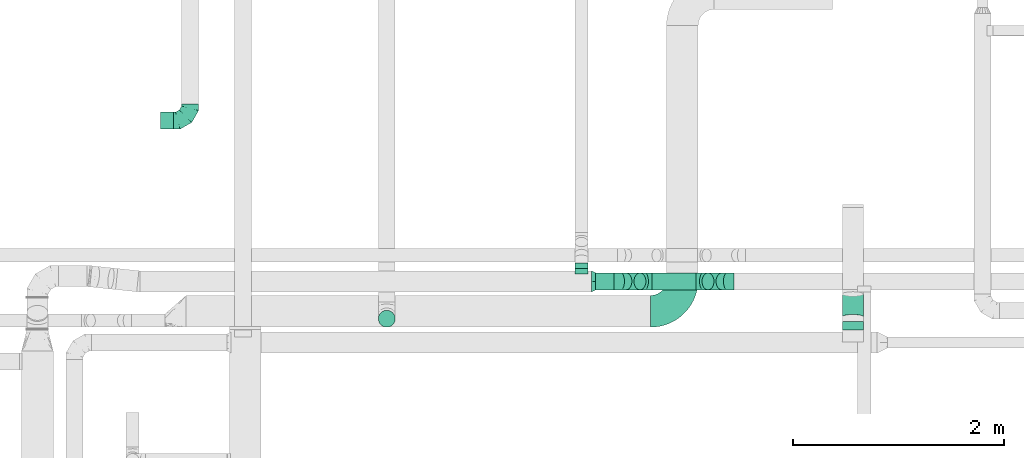
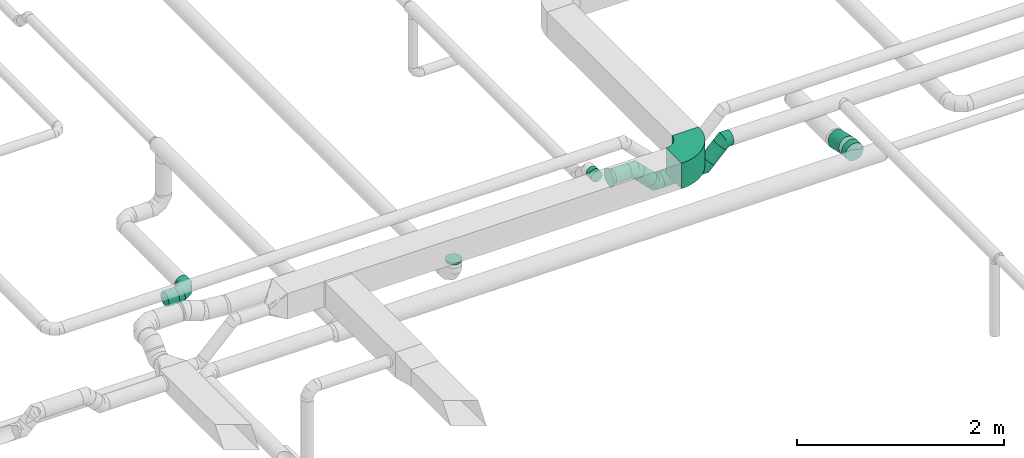
# One storey, part 17 of 60: 9 flow fittings, 8 flow segments.
"""IFC2X3 building model written with IfcOpenShell, lengths in millimetres."""

from ifc_helpers import new_model, entity, si_unit, converted_unit, derived_unit, direction, frame, frame_2d, origin, origin_2d_with_axis, place, context, subcontext, project, spatial, polyline, circle_curve, parameter, trimmed, segment, composite_curve, circle, outline, extrude, faceted_brep, source, transform, mapped, material, type_object, type_shapes, element, save


model = new_model("IFC2X3")

# Units and contexts
model_context = context("Model", 3, precision=0.01, world=origin(), true_north=direction((6.12303176911189e-17, 1.0)))
body_context = subcontext(model_context, "Body", "Model", "MODEL_VIEW")
ifc_project = project(units=[si_unit("LENGTHUNIT", "METRE", prefix="MILLI"), si_unit("AREAUNIT", "SQUARE_METRE"), si_unit("VOLUMEUNIT", "CUBIC_METRE"), converted_unit("PLANEANGLEUNIT", "DEGREE", entity("IfcRatioMeasure", 0.0174532925199433), si_unit("PLANEANGLEUNIT", "RADIAN"), dimensions=[0, 0, 0, 0, 0, 0, 0]), si_unit("MASSUNIT", "GRAM", prefix="KILO"), derived_unit("MASSDENSITYUNIT", [(si_unit("MASSUNIT", "GRAM", prefix="KILO"), 1), (si_unit("LENGTHUNIT", "METRE"), -3)]), derived_unit("MOMENTOFINERTIAUNIT", [(si_unit("LENGTHUNIT", "METRE"), 4)]), si_unit("TIMEUNIT", "SECOND"), si_unit("FREQUENCYUNIT", "HERTZ"), si_unit("THERMODYNAMICTEMPERATUREUNIT", "DEGREE_CELSIUS"), derived_unit("THERMALTRANSMITTANCEUNIT", [(si_unit("MASSUNIT", "GRAM", prefix="KILO"), 1), (si_unit("THERMODYNAMICTEMPERATUREUNIT", "KELVIN"), -1), (si_unit("TIMEUNIT", "SECOND"), -3)]), derived_unit("VOLUMETRICFLOWRATEUNIT", [(si_unit("LENGTHUNIT", "METRE"), 3), (si_unit("TIMEUNIT", "SECOND"), -1)]), derived_unit("MASSFLOWRATEUNIT", [(si_unit("MASSUNIT", "GRAM", prefix="KILO"), 1), (si_unit("TIMEUNIT", "SECOND"), -1)]), derived_unit("ROTATIONALFREQUENCYUNIT", [(si_unit("TIMEUNIT", "SECOND"), -1)]), si_unit("ELECTRICCURRENTUNIT", "AMPERE"), si_unit("ELECTRICVOLTAGEUNIT", "VOLT"), si_unit("POWERUNIT", "WATT"), si_unit("FORCEUNIT", "NEWTON", prefix="KILO"), si_unit("ILLUMINANCEUNIT", "LUX"), si_unit("LUMINOUSFLUXUNIT", "LUMEN"), si_unit("LUMINOUSINTENSITYUNIT", "CANDELA"), derived_unit("USERDEFINED", [(si_unit("MASSUNIT", "GRAM", prefix="KILO"), -1), (si_unit("LENGTHUNIT", "METRE"), -2), (si_unit("TIMEUNIT", "SECOND"), 3), (si_unit("LUMINOUSFLUXUNIT", "LUMEN"), 1)]), derived_unit("LINEARVELOCITYUNIT", [(si_unit("LENGTHUNIT", "METRE"), 1), (si_unit("TIMEUNIT", "SECOND"), -1)]), si_unit("PRESSUREUNIT", "PASCAL"), derived_unit("USERDEFINED", [(si_unit("LENGTHUNIT", "METRE"), -2), (si_unit("MASSUNIT", "GRAM", prefix="KILO"), 1), (si_unit("TIMEUNIT", "SECOND"), -2)]), derived_unit("LINEARFORCEUNIT", [(si_unit("MASSUNIT", "GRAM", prefix="KILO"), 1), (si_unit("LENGTHUNIT", "METRE"), 1), (si_unit("TIMEUNIT", "SECOND"), -2), (si_unit("LENGTHUNIT", "METRE"), -1)]), derived_unit("PLANARFORCEUNIT", [(si_unit("MASSUNIT", "GRAM", prefix="KILO"), 1), (si_unit("LENGTHUNIT", "METRE"), 1), (si_unit("TIMEUNIT", "SECOND"), -2), (si_unit("LENGTHUNIT", "METRE"), -2)])], contexts=[model_context])

# Site, building, storey
site_placement = place(None, origin())
site = spatial("IfcSite", under=ifc_project, at=site_placement, CompositionType="ELEMENT")
building_placement = place(site_placement, origin())
building = spatial("IfcBuilding", under=site, at=building_placement, CompositionType="ELEMENT")
storey_placement = place(building_placement, frame((0.0, 0.0, 19800.0)))
storey = spatial("IfcBuildingStorey", under=building, at=storey_placement, CompositionType="ELEMENT", Elevation=19800.0)

# Flow segments
duct_segment_type = type_object("IfcDuctSegmentType", PredefinedType="NOTDEFINED")
flow_segment_1_placement = place(storey_placement, frame((24261.71, 9620.18, 3098.4)))
element("IfcFlowSegment", 1, at=flow_segment_1_placement, inside=storey, type_object=duct_segment_type, context=body_context, shape_type="SweptSolid", body=[
    extrude(circle(Radius=100.0, at=origin_2d_with_axis()), frame((101.6, 0.15, 101.6), z_axis=(0.00148589656731399, 0.999998896055086, 0.0), x_axis=(0.999998896055086, -0.00148589656731399, 0.0)), (0.0, 0.0, 1.0), 77.0733326362623),
])
flow_segment_2_placement = place(storey_placement, frame((17815.33, 11516.5, 2478.4)))
element("IfcFlowSegment", 2, at=flow_segment_2_placement, inside=storey, type_object=duct_segment_type, context=body_context, shape_type="SweptSolid", body=[
    extrude(circle(Radius=80.0, at=origin_2d_with_axis()), frame((0.0, 81.6, 81.6), z_axis=(1.0, 0.0, 0.0), x_axis=(0.0, 1.0, 0.0)), (0.0, 0.0, 1.0), 120.000000000005),
])
flow_segment_3_placement = place(storey_placement, frame((21732.73, 10198.4, 3420.9)))
element("IfcFlowSegment", 3, at=flow_segment_3_placement, inside=storey, type_object=duct_segment_type, context=body_context, shape_type="SweptSolid", body=[
    extrude(circle(Radius=62.5, at=origin_2d_with_axis()), frame((64.1, 0.0, 64.1), z_axis=(0.0, 1.0, 0.0), x_axis=(1.0, 0.0, 0.0)), (0.0, 0.0, 1.0), 51.428036158612),
])
flow_segment_4_placement = place(storey_placement, frame((24261.86, 9718.29, 3046.09)))
element("IfcFlowSegment", 4, at=flow_segment_4_placement, inside=storey, type_object=duct_segment_type, context=body_context, shape_type="SweptSolid", body=[
    extrude(circle(Radius=100.0, at=origin_2d_with_axis()), frame((101.6, 239.69, 99.03), z_axis=(0.0, -0.974391220796743, 0.224859397922865), x_axis=(1.0, 0.0, 0.0)), (0.0, 0.0, 1.0), 221.277739853548),
])
flow_segment_5_placement = place(storey_placement, frame((21930.22, 9996.81, 3403.4)))
element("IfcFlowSegment", 5, at=flow_segment_5_placement, inside=storey, type_object=duct_segment_type, context=body_context, shape_type="SweptSolid", body=[
    extrude(circle(Radius=80.0, at=origin_2d_with_axis()), frame((0.0, 81.6, 81.6), z_axis=(1.0, 0.0, 0.0), x_axis=(0.0, -1.0, 0.0)), (0.0, 0.0, 1.0), 173.725830020329),
])
flow_segment_6_placement = place(storey_placement, frame((22158.92, 9996.81, 3247.42)))
element("IfcFlowSegment", 6, at=flow_segment_6_placement, inside=storey, type_object=duct_segment_type, context=body_context, shape_type="SweptSolid", body=[
    extrude(circle(Radius=80.0, at=origin_2d_with_axis()), frame((190.71, 81.6, 58.16), z_axis=(-0.70710678118654, 0.0, 0.707106781186555), x_axis=(0.0, -1.0, 0.0)), (0.0, 0.0, 1.0), 187.451660040623),
])
flow_segment_7_placement = place(storey_placement, frame((22462.77, 9996.81, 3177.13)))
element("IfcFlowSegment", 7, at=flow_segment_7_placement, inside=storey, type_object=duct_segment_type, context=body_context, shape_type="SweptSolid", body=[
    extrude(circle(Radius=80.0, at=origin_2d_with_axis()), frame((0.0, 81.6, 81.6), z_axis=(1.0, 0.0, 0.0), x_axis=(0.0, -1.0, 0.0)), (0.0, 0.0, 1.0), 417.451660040577),
])
flow_segment_8_placement = place(storey_placement, frame((22935.19, 9996.81, 3247.42)))
element("IfcFlowSegment", 8, at=flow_segment_8_placement, inside=storey, type_object=duct_segment_type, context=body_context, shape_type="SweptSolid", body=[
    extrude(circle(Radius=80.0, at=origin_2d_with_axis()), frame((58.16, 81.6, 58.16), z_axis=(0.707106781186557, 0.0, 0.707106781186538), x_axis=(0.0, -1.0, 0.0)), (0.0, 0.0, 1.0), 187.45166004063),
])

# Flow fittings
ifc_material = material()
duct_fitting_type_1 = type_object("IfcDuctFittingType", PredefinedType="NOTDEFINED", material=ifc_material)
shared_shape_1 = source(origin(), body_context, "Body", "Brep", [
    faceted_brep([(-160.0, 0.0, -80.0), (-160.0, -20.71, -77.27), (-160.0, -40.0, -69.28), (-160.0, -56.57, -56.57), (-160.0, -69.28, -40.0), (-160.0, -77.27, -20.71), (-160.0, -80.0, 0.0), (-160.0, -77.27, 20.71), (-160.0, -69.28, 40.0), (-160.0, -56.57, 56.57), (-160.0, -40.0, 69.28), (-160.0, -20.71, 77.27), (-160.0, 0.0, 80.0), (-160.0, 20.71, 77.27), (-160.0, 40.0, 69.28), (-160.0, 56.57, 56.57), (-160.0, 69.28, 40.0), (-160.0, 77.27, 20.71), (-160.0, 80.0, 0.0), (-160.0, 77.27, -20.71), (-160.0, 69.28, -40.0), (-160.0, 56.57, -56.57), (-160.0, 40.0, -69.28), (-160.0, 20.71, -77.27), (-122.68, 20.71, 77.27), (-127.85, 40.0, 69.28), (-117.13, 0.0, 80.0), (-132.29, 56.57, 56.57), (-137.83, 77.27, 20.71), (-138.56, 80.0, 0.0), (-135.69, 69.28, 40.0), (-135.69, 69.28, -40.0), (-132.29, 56.57, -56.57), (-137.83, 77.27, -20.71), (-122.68, 20.71, -77.27), (-117.13, 0.0, -80.0), (-127.85, 40.0, -69.28), (-111.58, -20.71, -77.27), (-106.41, -40.0, -69.28), (-101.97, -56.57, -56.57), (-98.56, -69.28, -40.0), (-96.42, -77.27, -20.71), (-95.69, -80.0, 0.0), (-96.42, -77.27, 20.71), (-98.56, -69.28, 40.0), (-101.97, -56.57, 56.57), (-106.41, -40.0, 69.28), (-111.58, -20.71, 77.27), (-58.03, 58.03, 77.27), (-72.15, 72.15, 69.28), (-42.87, 42.87, 80.0), (-84.28, 84.28, 56.57), (-93.59, 93.59, 40.0), (-99.44, 99.44, 20.71), (-101.44, 101.44, 0.0), (-99.44, 99.44, -20.71), (-93.59, 93.59, -40.0), (-84.28, 84.28, -56.57), (-58.03, 58.03, -77.27), (-42.87, 42.87, -80.0), (-72.15, 72.15, -69.28), (-27.71, 27.71, -77.27), (-13.59, 13.59, -69.28), (-1.46, 1.46, -56.57), (7.85, -7.85, -40.0), (13.7, -13.7, -20.71), (15.69, -15.69, 0.0), (13.7, -13.7, 20.71), (7.85, -7.85, 40.0), (-1.46, 1.46, 56.57), (-13.59, 13.59, 69.28), (-27.71, 27.71, 77.27), (-20.71, 122.68, 77.27), (-40.0, 127.85, 69.28), (0.0, 117.13, 80.0), (-56.57, 132.29, 56.57), (-69.28, 135.69, 40.0), (-77.27, 137.83, 20.71), (-80.0, 138.56, 0.0), (-77.27, 137.83, -20.71), (-69.28, 135.69, -40.0), (-56.57, 132.29, -56.57), (-20.71, 122.68, -77.27), (0.0, 117.13, -80.0), (-40.0, 127.85, -69.28), (20.71, 111.58, -77.27), (40.0, 106.41, -69.28), (56.57, 101.97, -56.57), (69.28, 98.56, -40.0), (77.27, 96.42, -20.71), (80.0, 95.69, 0.0), (77.27, 96.42, 20.71), (69.28, 98.56, 40.0), (56.57, 101.97, 56.57), (40.0, 106.41, 69.28), (20.71, 111.58, 77.27), (-20.71, 160.0, -77.27), (-40.0, 160.0, -69.28), (-56.57, 160.0, -56.57), (-69.28, 160.0, -40.0), (-77.27, 160.0, -20.71), (-80.0, 160.0, 0.0), (-77.27, 160.0, 20.71), (-69.28, 160.0, 40.0), (-56.57, 160.0, 56.57), (-40.0, 160.0, 69.28), (-20.71, 160.0, 77.27), (0.0, 160.0, 80.0), (20.71, 160.0, 77.27), (40.0, 160.0, 69.28), (56.57, 160.0, 56.57), (69.28, 160.0, 40.0), (77.27, 160.0, 20.71), (80.0, 160.0, 0.0), (77.27, 160.0, -20.71), (69.28, 160.0, -40.0), (56.57, 160.0, -56.57), (40.0, 160.0, -69.28), (20.71, 160.0, -77.27), (0.0, 160.0, -80.0)], [[[0, 1, 2, 3, 4, 5, 6, 7, 8, 9, 10, 11, 12, 13, 14, 15, 16, 17, 18, 19, 20, 21, 22, 23]], [[24, 25, 14, 13]], [[26, 24, 13, 12]], [[14, 25, 27, 15]], [[28, 29, 18, 17]], [[30, 28, 17, 16]], [[15, 27, 30, 16]], [[20, 31, 32, 21]], [[33, 31, 20, 19]], [[18, 29, 33, 19]], [[34, 35, 0, 23]], [[36, 34, 23, 22]], [[32, 36, 22, 21]], [[1, 0, 35, 37]], [[2, 1, 37, 38]], [[3, 2, 38, 39]], [[5, 4, 40, 41]], [[6, 5, 41, 42]], [[39, 40, 4, 3]], [[6, 42, 43, 7]], [[7, 43, 44, 8]], [[8, 44, 45, 9]], [[9, 45, 46, 10]], [[10, 46, 47, 11]], [[26, 12, 11, 47]], [[48, 49, 25, 24]], [[50, 48, 24, 26]], [[27, 25, 49, 51]], [[52, 53, 28, 30]], [[51, 52, 30, 27]], [[29, 28, 53, 54]], [[55, 56, 31, 33]], [[54, 55, 33, 29]], [[32, 31, 56, 57]], [[58, 59, 35, 34]], [[60, 58, 34, 36]], [[57, 60, 36, 32]], [[37, 35, 59, 61]], [[38, 37, 61, 62]], [[39, 38, 62, 63]], [[41, 40, 64, 65]], [[42, 41, 65, 66]], [[63, 64, 40, 39]], [[43, 42, 66, 67]], [[44, 43, 67, 68]], [[68, 69, 45, 44]], [[46, 45, 69, 70]], [[47, 46, 70, 71]], [[26, 47, 71, 50]], [[72, 73, 49, 48]], [[74, 72, 48, 50]], [[51, 49, 73, 75]], [[76, 77, 53, 52]], [[75, 76, 52, 51]], [[54, 53, 77, 78]], [[79, 80, 56, 55]], [[78, 79, 55, 54]], [[57, 56, 80, 81]], [[82, 83, 59, 58]], [[84, 82, 58, 60]], [[81, 84, 60, 57]], [[61, 59, 83, 85]], [[62, 61, 85, 86]], [[63, 62, 86, 87]], [[65, 64, 88, 89]], [[66, 65, 89, 90]], [[87, 88, 64, 63]], [[67, 66, 90, 91]], [[68, 67, 91, 92]], [[92, 93, 69, 68]], [[70, 69, 93, 94]], [[71, 70, 94, 95]], [[50, 71, 95, 74]], [[96, 97, 98, 99, 100, 101, 102, 103, 104, 105, 106, 107, 108, 109, 110, 111, 112, 113, 114, 115, 116, 117, 118, 119]], [[72, 74, 107, 106]], [[73, 72, 106, 105]], [[75, 73, 105, 104]], [[77, 76, 103, 102]], [[78, 77, 102, 101]], [[75, 104, 103, 76]], [[78, 101, 100, 79]], [[79, 100, 99, 80]], [[80, 99, 98, 81]], [[84, 97, 96, 82]], [[82, 96, 119, 83]], [[84, 81, 98, 97]], [[118, 117, 86, 85]], [[119, 118, 85, 83]], [[116, 87, 86, 117]], [[88, 115, 114, 89]], [[89, 114, 113, 90]], [[115, 88, 87, 116]], [[112, 111, 92, 91]], [[113, 112, 91, 90]], [[111, 110, 93, 92]], [[95, 94, 109, 108]], [[74, 95, 108, 107]], [[110, 109, 94, 93]]]),
])
type_shapes(duct_fitting_type_1, [shared_shape_1])
flow_fitting_1_placement = place(storey_placement, frame((18095.33, 11598.09, 2560.0)))
element("IfcFlowFitting", 9, at=flow_fitting_1_placement, inside=storey, type_object=duct_fitting_type_1, material=ifc_material, context=body_context, shape_type="MappedRepresentation", body=[
    mapped(shared_shape_1, transform((0.0, 0.0, 0.0), scale=1.0)),
])
duct_fitting_type_2 = type_object("IfcDuctFittingType", PredefinedType="NOTDEFINED", material=ifc_material)
shared_shape_2 = source(origin(), body_context, "Body", "Brep", [
    faceted_brep([(-66.27, 0.0, -80.0), (-66.27, -20.71, -77.27), (-66.27, -40.0, -69.28), (-66.27, -56.57, -56.57), (-66.27, -69.28, -40.0), (-66.27, -77.27, -20.71), (-66.27, -80.0, 0.0), (-66.27, -77.27, 20.71), (-66.27, -69.28, 40.0), (-66.27, -56.57, 56.57), (-66.27, -40.0, 69.28), (-66.27, -20.71, 77.27), (-66.27, 0.0, 80.0), (-66.27, 20.71, 77.27), (-66.27, 40.0, 69.28), (-66.27, 56.57, 56.57), (-66.27, 69.28, 40.0), (-66.27, 77.27, 20.71), (-66.27, 80.0, 0.0), (-66.27, 77.27, -20.71), (-66.27, 69.28, -40.0), (-66.27, 56.57, -56.57), (-66.27, 40.0, -69.28), (-66.27, 20.71, -77.27), (-8.58, 20.71, 77.27), (-16.57, 40.0, 69.28), (0.0, 0.0, 80.0), (-23.43, 56.57, 56.57), (-28.7, 69.28, 40.0), (-32.01, 77.27, 20.71), (-33.14, 80.0, 0.0), (-32.01, 77.27, -20.71), (-28.7, 69.28, -40.0), (-23.43, 56.57, -56.57), (-8.58, 20.71, -77.27), (0.0, 0.0, -80.0), (-16.57, 40.0, -69.28), (8.58, -20.71, -77.27), (16.57, -40.0, -69.28), (23.43, -56.57, -56.57), (28.7, -69.28, -40.0), (32.01, -77.27, -20.71), (33.14, -80.0, 0.0), (32.01, -77.27, 20.71), (28.7, -69.28, 40.0), (23.43, -56.57, 56.57), (16.57, -40.0, 69.28), (8.58, -20.71, 77.27), (46.86, 46.86, 80.0), (32.22, 61.5, 77.27), (18.58, 75.15, 69.28), (6.86, 86.86, 56.57), (-2.13, 95.85, 40.0), (-7.78, 101.5, 20.71), (-9.71, 103.43, 0.0), (-7.78, 101.5, -20.71), (-2.13, 95.85, -40.0), (6.86, 86.86, -56.57), (18.58, 75.15, -69.28), (32.22, 61.5, -77.27), (46.86, 46.86, -80.0), (61.5, 32.22, -77.27), (75.15, 18.58, -69.28), (86.86, 6.86, -56.57), (95.85, -2.13, -40.0), (101.5, -7.78, -20.71), (103.43, -9.71, 0.0), (101.5, -7.78, 20.71), (95.85, -2.13, 40.0), (86.86, 6.86, 56.57), (75.15, 18.58, 69.28), (61.5, 32.22, 77.27)], [[[0, 1, 2, 3, 4, 5, 6, 7, 8, 9, 10, 11, 12, 13, 14, 15, 16, 17, 18, 19, 20, 21, 22, 23]], [[24, 25, 14, 13]], [[26, 24, 13, 12]], [[14, 25, 27, 15]], [[28, 29, 17, 16]], [[28, 16, 15, 27]], [[30, 18, 17, 29]], [[31, 32, 20, 19]], [[30, 31, 19, 18]], [[32, 33, 21, 20]], [[34, 35, 0, 23]], [[36, 34, 23, 22]], [[33, 36, 22, 21]], [[1, 0, 35, 37]], [[2, 1, 37, 38]], [[38, 39, 3, 2]], [[5, 4, 40, 41]], [[6, 5, 41, 42]], [[39, 40, 4, 3]], [[6, 42, 43, 7]], [[7, 43, 44, 8]], [[8, 44, 45, 9]], [[9, 45, 46, 10]], [[10, 46, 47, 11]], [[26, 12, 11, 47]], [[24, 26, 48, 49]], [[25, 24, 49, 50]], [[27, 25, 50, 51]], [[29, 28, 52, 53]], [[30, 29, 53, 54]], [[51, 52, 28, 27]], [[30, 54, 55, 31]], [[31, 55, 56, 32]], [[57, 33, 32, 56]], [[36, 58, 59, 34]], [[34, 59, 60, 35]], [[58, 36, 33, 57]], [[35, 60, 61, 37]], [[37, 61, 62, 38]], [[63, 39, 38, 62]], [[40, 64, 65, 41]], [[41, 65, 66, 42]], [[64, 40, 39, 63]], [[43, 42, 66, 67]], [[44, 43, 67, 68]], [[68, 69, 45, 44]], [[47, 46, 70, 71]], [[26, 47, 71, 48]], [[69, 70, 46, 45]], [[59, 58, 57, 56, 55, 54, 53, 52, 51, 50, 49, 48, 71, 70, 69, 68, 67, 66, 65, 64, 63, 62, 61, 60]]]),
])
type_shapes(duct_fitting_type_2, [shared_shape_2])
for number, where, z_axis, x_axis in (
    (10, (22170.22, 10078.4, 3485.0), (0.0, 1.0, 0.0), (1.0, 0.0, 0.0)),
    (11, (22396.49, 10078.4, 3258.73), (0.0, -1.0, 0.0), (0.707106781186522, 0.0, -0.707106781186573)),
    (12, (22946.49, 10078.4, 3258.73), (0.0, -1.0, 0.0), (1.0, 0.0, 0.0)),
    (13, (23172.77, 10078.4, 3485.0), (0.0, 1.0, 0.0), (0.70710678118649, 0.0, 0.707106781186605)),
):
    element("IfcFlowFitting", number, at=place(storey_placement, frame(where, z_axis=z_axis, x_axis=x_axis)), inside=storey, type_object=duct_fitting_type_2, material=ifc_material, context=body_context, shape_type="MappedRepresentation", body=[
        mapped(shared_shape_2, transform((0.0, 0.0, 0.0), scale=1.0)),
    ])
duct_fitting_type_3 = type_object("IfcDuctFittingType", PredefinedType="NOTDEFINED", material=ifc_material)
shared_shape_3 = source(origin(), body_context, "Body", "Brep", [
    faceted_brep([(40.0, -73.91, 30.61), (40.0, -76.96, 15.31), (40.0, -80.0, 0.0), (40.0, -76.96, -15.31), (40.0, -73.91, -30.61), (40.0, -65.24, -43.59), (40.0, -56.57, -56.57), (40.0, -43.59, -65.24), (40.0, -30.61, -73.91), (40.0, -15.31, -76.96), (40.0, 0.0, -80.0), (40.0, 15.31, -76.96), (40.0, 30.61, -73.91), (40.0, 43.59, -65.24), (40.0, 56.57, -56.57), (40.0, 65.24, -43.59), (40.0, 73.91, -30.61), (40.0, 76.96, -15.31), (40.0, 80.0, 0.0), (40.0, 76.96, 15.31), (40.0, 73.91, 30.61), (40.0, 65.24, 43.59), (40.0, 56.57, 56.57), (40.0, 43.59, 65.24), (40.0, 30.61, 73.91), (40.0, 15.31, 76.96), (40.0, 0.0, 80.0), (40.0, -15.31, 76.96), (40.0, -30.61, 73.91), (40.0, -43.59, 65.24), (40.0, -56.57, 56.57), (40.0, -65.24, 43.59), (0.0, -100.0, 0.0), (0.0, -95.11, 30.9), (0.0, -80.9, 58.78), (0.0, -58.78, 80.9), (0.0, -30.9, 95.11), (0.0, 0.0, 100.0), (0.0, 30.9, 95.11), (0.0, 58.78, 80.9), (0.0, 80.9, 58.78), (0.0, 95.11, 30.9), (0.0, 100.0, 0.0), (0.0, 95.11, -30.9), (0.0, 80.9, -58.78), (0.0, 58.78, -80.9), (0.0, 30.9, -95.11), (0.0, 0.0, -100.0), (0.0, -30.9, -95.11), (0.0, -58.78, -80.9), (0.0, -80.9, -58.78), (0.0, -95.11, -30.9)], [[[0, 1, 2, 3, 4, 5, 6, 7, 8, 9, 10, 11, 12, 13, 14, 15, 16, 17, 18, 19, 20, 21, 22, 23, 24, 25, 26, 27, 28, 29, 30, 31]], [[32, 33, 34, 35, 36, 37, 38, 39, 40, 41, 42, 43, 44, 45, 46, 47, 48, 49, 50, 51]], [[37, 25, 38]], [[25, 24, 38]], [[24, 39, 38]], [[41, 20, 19]], [[25, 37, 26]], [[39, 24, 23, 22]], [[42, 19, 18]], [[20, 40, 22, 21]], [[41, 40, 20]], [[42, 41, 19]], [[22, 40, 39]], [[32, 1, 33]], [[1, 0, 33]], [[0, 34, 33]], [[36, 28, 27]], [[1, 32, 2]], [[34, 0, 31, 30]], [[37, 27, 26]], [[28, 35, 30, 29]], [[36, 35, 28]], [[37, 36, 27]], [[30, 35, 34]], [[47, 9, 48]], [[9, 8, 48]], [[8, 49, 48]], [[51, 4, 3]], [[9, 47, 10]], [[49, 8, 7, 6]], [[32, 3, 2]], [[4, 50, 6, 5]], [[51, 50, 4]], [[32, 51, 3]], [[6, 50, 49]], [[42, 17, 43]], [[17, 16, 43]], [[16, 44, 43]], [[46, 12, 11]], [[17, 42, 18]], [[44, 16, 15, 14]], [[47, 11, 10]], [[12, 45, 14, 13]], [[46, 45, 12]], [[47, 46, 11]], [[14, 45, 44]]]),
])
type_shapes(duct_fitting_type_3, [shared_shape_3])
flow_fitting_2_placement = place(storey_placement, frame((21890.22, 10078.4, 3485.0)))
element("IfcFlowFitting", 14, at=flow_fitting_2_placement, inside=storey, type_object=duct_fitting_type_3, material=ifc_material, context=body_context, shape_type="MappedRepresentation", body=[
    mapped(shared_shape_3, transform((0.0, 0.0, 0.0), scale=1.0)),
])
duct_fitting_type_4 = type_object("IfcDuctFittingType", PredefinedType="NOTDEFINED", material=ifc_material)
shared_shape_4 = source(origin(), body_context, "Body", "Brep", [
    faceted_brep([(20.0, 20.71, -77.27), (20.0, 40.0, -69.28), (20.0, 56.57, -56.57), (20.0, 69.28, -40.0), (20.0, 77.27, -20.71), (20.0, 80.0, 0.0), (20.0, 77.27, 20.71), (20.0, 69.28, 40.0), (20.0, 56.57, 56.57), (20.0, 40.0, 69.28), (20.0, 20.71, 77.27), (20.0, 0.0, 80.0), (20.0, -20.71, 77.27), (20.0, -40.0, 69.28), (20.0, -56.57, 56.57), (20.0, -69.28, 40.0), (20.0, -77.27, 20.71), (20.0, -80.0, 0.0), (20.0, -77.27, -20.71), (20.0, -69.28, -40.0), (20.0, -56.57, -56.57), (20.0, -40.0, -69.28), (20.0, -20.71, -77.27), (20.0, 0.0, -80.0), (0.0, 0.0, 80.0), (0.0, 20.71, 77.27), (-6.1, 20.71, 77.27), (-6.1, 0.0, 80.0), (0.0, 40.0, 69.28), (-6.1, 40.0, 69.28), (0.0, 56.57, 56.57), (-6.1, 56.57, 56.57), (0.0, 69.28, 40.0), (0.0, 77.27, 20.71), (-6.1, 77.27, 20.71), (-6.1, 69.28, 40.0), (0.0, 80.0, 0.0), (-6.1, 80.0, 0.0), (0.0, 77.27, -20.71), (-6.1, 77.27, -20.71), (0.0, 69.28, -40.0), (-6.1, 69.28, -40.0), (0.0, 56.57, -56.57), (-6.1, 56.57, -56.57), (0.0, 40.0, -69.28), (0.0, 20.71, -77.27), (-6.1, 20.71, -77.27), (-6.1, 40.0, -69.28), (0.0, 0.0, -80.0), (-6.1, 0.0, -80.0), (0.0, -20.71, -77.27), (-6.1, -20.71, -77.27), (0.0, -40.0, -69.28), (-6.1, -40.0, -69.28), (0.0, -56.57, -56.57), (-6.1, -56.57, -56.57), (0.0, -69.28, -40.0), (0.0, -77.27, -20.71), (-6.1, -77.27, -20.71), (-6.1, -69.28, -40.0), (0.0, -80.0, 0.0), (-6.1, -80.0, 0.0), (0.0, -77.27, 20.71), (-6.1, -77.27, 20.71), (0.0, -69.28, 40.0), (-6.1, -69.28, 40.0), (0.0, -56.57, 56.57), (-6.1, -56.57, 56.57), (0.0, -40.0, 69.28), (0.0, -20.71, 77.27), (-6.1, -20.71, 77.27), (-6.1, -40.0, 69.28)], [[[0, 1, 2, 3, 4, 5, 6, 7, 8, 9, 10, 11, 12, 13, 14, 15, 16, 17, 18, 19, 20, 21, 22, 23]], [[24, 11, 10, 25, 26, 27]], [[25, 10, 9, 28, 29, 26]], [[28, 9, 8, 30, 31, 29]], [[32, 7, 6, 33, 34, 35]], [[33, 6, 5, 36, 37, 34]], [[30, 8, 7, 32, 35, 31]], [[36, 5, 4, 38, 39, 37]], [[38, 4, 3, 40, 41, 39]], [[40, 3, 2, 42, 43, 41]], [[44, 1, 0, 45, 46, 47]], [[45, 0, 23, 48, 49, 46]], [[42, 2, 1, 44, 47, 43]], [[48, 23, 22, 50, 51, 49]], [[50, 22, 21, 52, 53, 51]], [[52, 21, 20, 54, 55, 53]], [[56, 19, 18, 57, 58, 59]], [[57, 18, 17, 60, 61, 58]], [[54, 20, 19, 56, 59, 55]], [[60, 17, 16, 62, 63, 61]], [[62, 16, 15, 64, 65, 63]], [[64, 15, 14, 66, 67, 65]], [[68, 13, 12, 69, 70, 71]], [[69, 12, 11, 24, 27, 70]], [[66, 14, 13, 68, 71, 67]], [[49, 51, 53, 55, 59, 58, 61, 63, 65, 67, 71, 70, 27, 26, 29, 31, 35, 34, 37, 39, 41, 43, 47, 46]]]),
])
type_shapes(duct_fitting_type_4, [shared_shape_4])
flow_fitting_3_placement = place(storey_placement, frame((19955.04, 9725.16, 3420.0), z_axis=(0.0, 1.0, 0.0), x_axis=(0.0, 0.0, -1.0)))
element("IfcFlowFitting", 15, at=flow_fitting_3_placement, inside=storey, type_object=duct_fitting_type_4, material=ifc_material, context=body_context, shape_type="MappedRepresentation", body=[
    mapped(shared_shape_4, transform((0.0, 0.0, 0.0), scale=1.0)),
])
duct_fitting_type_5 = type_object("IfcDuctFittingType", PredefinedType="NOTDEFINED", material=ifc_material)
shared_shape_5 = source(origin(), body_context, "Body", "Brep", [
    faceted_brep([(20.0, 0.0, -62.5), (20.0, 16.18, -60.37), (20.0, 31.25, -54.13), (20.0, 44.19, -44.19), (20.0, 54.13, -31.25), (20.0, 60.37, -16.18), (20.0, 62.5, 0.0), (20.0, 60.37, 16.18), (20.0, 54.13, 31.25), (20.0, 44.19, 44.19), (20.0, 31.25, 54.13), (20.0, 16.18, 60.37), (20.0, 0.0, 62.5), (20.0, -16.18, 60.37), (20.0, -31.25, 54.13), (20.0, -44.19, 44.19), (20.0, -54.13, 31.25), (20.0, -60.37, 16.18), (20.0, -62.5, 0.0), (20.0, -60.37, -16.18), (20.0, -54.13, -31.25), (20.0, -44.19, -44.19), (20.0, -31.25, -54.13), (20.0, -16.18, -60.37), (0.0, 0.0, 62.5), (-28.03, 0.0, 62.5), (-28.03, -16.18, 60.37), (0.0, -16.18, 60.37), (-28.03, -31.25, 54.13), (0.0, -31.25, 54.13), (0.0, -44.19, 44.19), (-28.03, -44.19, 44.19), (0.0, -54.13, 31.25), (-28.03, -54.13, 31.25), (-28.03, -60.37, 16.18), (0.0, -60.37, 16.18), (-28.03, -62.5, 0.0), (0.0, -62.5, 0.0), (-28.03, -60.37, -16.18), (0.0, -60.37, -16.18), (-28.03, -54.13, -31.25), (0.0, -54.13, -31.25), (0.0, -44.19, -44.19), (-28.03, -44.19, -44.19), (0.0, -31.25, -54.13), (-28.03, -31.25, -54.13), (-28.03, -16.18, -60.37), (0.0, -16.18, -60.37), (-28.03, 0.0, -62.5), (0.0, 0.0, -62.5), (-28.03, 16.18, -60.37), (0.0, 16.18, -60.37), (-28.03, 31.25, -54.13), (0.0, 31.25, -54.13), (0.0, 44.19, -44.19), (-28.03, 44.19, -44.19), (0.0, 54.13, -31.25), (-28.03, 54.13, -31.25), (-28.03, 60.37, -16.18), (0.0, 60.37, -16.18), (-28.03, 62.5, 0.0), (0.0, 62.5, 0.0), (-28.03, 60.37, 16.18), (0.0, 60.37, 16.18), (-28.03, 54.13, 31.25), (0.0, 54.13, 31.25), (0.0, 44.19, 44.19), (-28.03, 44.19, 44.19), (0.0, 31.25, 54.13), (-28.03, 31.25, 54.13), (-28.03, 16.18, 60.37), (0.0, 16.18, 60.37)], [[[0, 1, 2, 3, 4, 5, 6, 7, 8, 9, 10, 11, 12, 13, 14, 15, 16, 17, 18, 19, 20, 21, 22, 23]], [[13, 12, 24, 25, 26, 27]], [[14, 13, 27, 26, 28, 29]], [[30, 15, 14, 29, 28, 31]], [[17, 16, 32, 33, 34, 35]], [[18, 17, 35, 34, 36, 37]], [[32, 16, 15, 30, 31, 33]], [[19, 18, 37, 36, 38, 39]], [[20, 19, 39, 38, 40, 41]], [[42, 21, 20, 41, 40, 43]], [[23, 22, 44, 45, 46, 47]], [[0, 23, 47, 46, 48, 49]], [[44, 22, 21, 42, 43, 45]], [[1, 0, 49, 48, 50, 51]], [[2, 1, 51, 50, 52, 53]], [[54, 3, 2, 53, 52, 55]], [[5, 4, 56, 57, 58, 59]], [[6, 5, 59, 58, 60, 61]], [[56, 4, 3, 54, 55, 57]], [[7, 6, 61, 60, 62, 63]], [[8, 7, 63, 62, 64, 65]], [[66, 9, 8, 65, 64, 67]], [[11, 10, 68, 69, 70, 71]], [[12, 11, 71, 70, 25, 24]], [[68, 10, 9, 66, 67, 69]], [[46, 45, 43, 40, 38, 36, 34, 33, 31, 28, 26, 25, 70, 69, 67, 64, 62, 60, 58, 57, 55, 52, 50, 48]]]),
])
type_shapes(duct_fitting_type_5, [shared_shape_5])
flow_fitting_4_placement = place(storey_placement, frame((21796.82, 10178.4, 3485.0), z_axis=(0.0, 0.0, -1.0), x_axis=(0.0, 1.0, 0.0)))
element("IfcFlowFitting", 16, at=flow_fitting_4_placement, inside=storey, type_object=duct_fitting_type_5, material=ifc_material, context=body_context, shape_type="MappedRepresentation", body=[
    mapped(shared_shape_5, transform((0.0, 0.0, 0.0), scale=1.0)),
])
duct_fitting_type_6 = type_object("IfcDuctFittingType", PredefinedType="NOTDEFINED", material=ifc_material)
shared_shape_6 = source(origin(), body_context, "Body", "SweptSolid", [
    extrude(outline(composite_curve([segment(polyline([(-300.0, -150.0), (0.0, -150.0)]), True, "CONTINUOUS"), segment(trimmed(circle_curve(frame_2d((150.0, -150.0), x_axis=(0.0, 1.0)), 150.0), [parameter(0.0)], [parameter(90.0)], True, "PARAMETER"), False, "CONTINUOUS"), segment(polyline([(150.0, 0.0), (150.0, 300.0)]), True, "CONTINUOUS"), segment(trimmed(circle_curve(frame_2d((150.0, -150.0), x_axis=(0.0, 1.0)), 450.0), [parameter(0.0)], [parameter(90.0000000000001)], True, "PARAMETER"), True, "CONTINUOUS")], self_intersect=False)), frame((-150.0, 150.0, -150.0), z_axis=(0.0, 0.0, 1.0), x_axis=(-1.0, 0.0, 0.0)), (0.0, 0.0, 1.0), 300.0),
])
type_shapes(duct_fitting_type_6, [shared_shape_6])
flow_fitting_5_placement = place(storey_placement, frame((22750.9, 9795.16, 3570.0)))
element("IfcFlowFitting", 17, at=flow_fitting_5_placement, inside=storey, type_object=duct_fitting_type_6, material=ifc_material, context=body_context, shape_type="MappedRepresentation", body=[
    mapped(shared_shape_6, transform((0.0, 0.0, 0.0), scale=1.0)),
])

save(model, "model.ifc")
